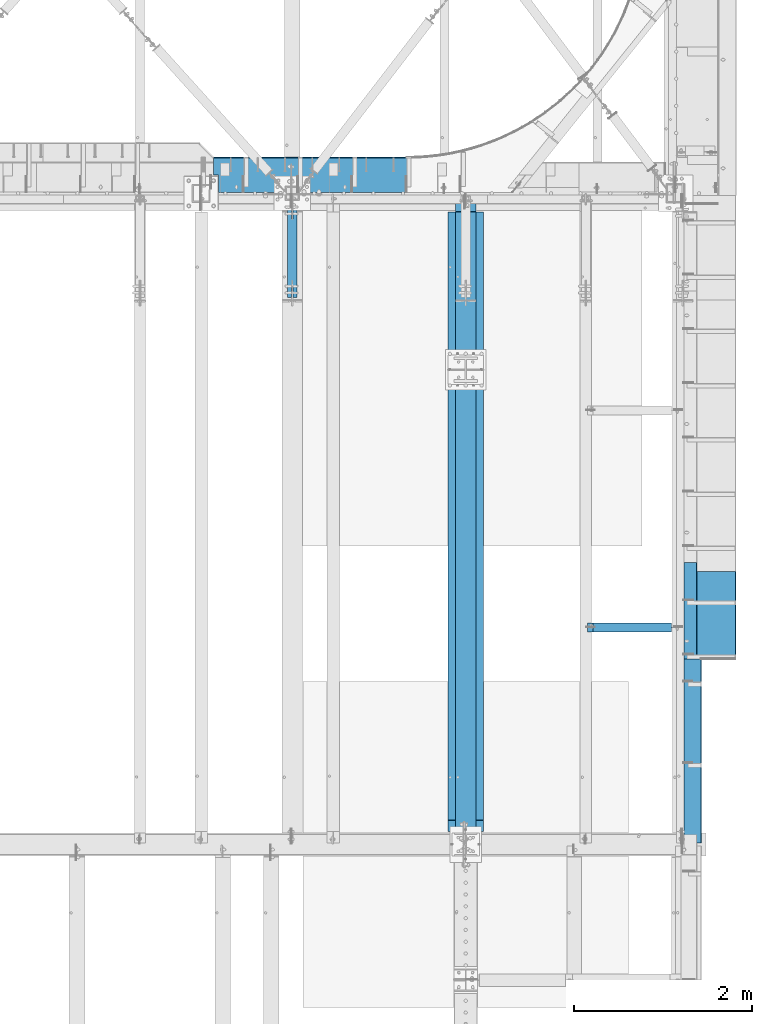
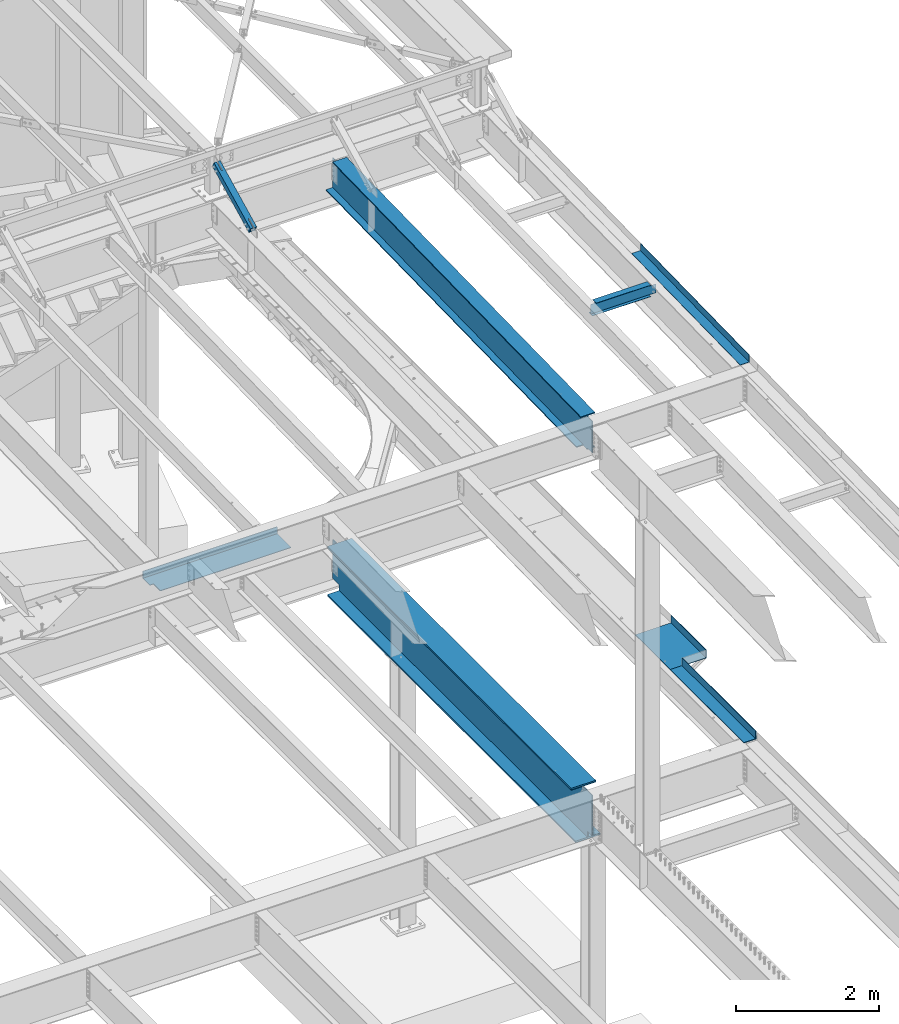
# One storey, part 1163 of 1763: 7 beams, 1 member, 7 elements without a shape of their own.
"""IFC2X3 building model written with IfcOpenShell, lengths in millimetres."""

from ifc_helpers import new_model, si_unit, frame, origin_with_axes, place, context, subcontext, project, spatial, faceted_brep, material, type_object, element, aggregate, save


model = new_model("IFC2X3")

# Units and contexts
model_context = context("Model", 3, precision=1e-05, world=origin_with_axes())
body_context = subcontext(model_context, "Body", "Model", "MODEL_VIEW")
ifc_project = project(units=[si_unit("LENGTHUNIT", "METRE", prefix="MILLI"), si_unit("AREAUNIT", "SQUARE_METRE"), si_unit("VOLUMEUNIT", "CUBIC_METRE"), si_unit("MASSUNIT", "GRAM", prefix="KILO"), si_unit("TIMEUNIT", "SECOND"), si_unit("PLANEANGLEUNIT", "RADIAN"), si_unit("SOLIDANGLEUNIT", "STERADIAN"), si_unit("THERMODYNAMICTEMPERATUREUNIT", "DEGREE_CELSIUS"), si_unit("LUMINOUSINTENSITYUNIT", "LUMEN")], contexts=[model_context])

# Site, building, storey
site_placement = place(None, origin_with_axes())
site = spatial("IfcSite", under=ifc_project, at=site_placement, CompositionType="ELEMENT")
building_placement = place(site_placement, origin_with_axes())
building = spatial("IfcBuilding", under=site, at=building_placement, Name="Undefined", CompositionType="ELEMENT")
storey_placement = place(building_placement, origin_with_axes())
storey = spatial("IfcBuildingStorey", under=building, at=storey_placement, Name="Undefined", CompositionType="ELEMENT", Elevation=0.0)

# Assembly, beam
assembly_1_placement = place(storey_placement, origin_with_axes())
assembly_1 = element("IfcElementAssembly", 1, at=assembly_1_placement, inside=storey, Name="BEAM", AssemblyPlace="NOTDEFINED", PredefinedType="RIGID_FRAME")
ifc_material_1 = material(Name="STEEL/A36")
beam_type_1 = type_object("IfcBeamType", PredefinedType="NOTDEFINED")
beam_1_placement = place(assembly_1_placement, frame((-21576.7372736984, 47380.525, 5199.0625), z_axis=(0.0, -1.0, 0.0), x_axis=(1.0, 0.0, 0.0)))
beam_1 = element("IfcBeam", 2, at=beam_1_placement, type_object=beam_type_1, material=ifc_material_1, Name="BENT_PLATE", context=body_context, shape_type="Brep", body=[
    faceted_brep([(0.0, -4.76249999999982, -492.125), (0.0, -4.76249999999982, 492.125), (0.0, 4.76249999999982, 492.125), (0.0, 4.76249999999982, -492.125), (577.849999999999, 4.76249999999982, 492.125), (577.849999999999, 4.76249999999982, -492.125), (587.375, -4.76249999999982, -492.125), (587.375, -4.76249999999982, 492.125), (577.849999999999, 134.937496948242, 492.125), (577.849999999999, 134.937496948242, -492.125), (587.375, 134.937496948242, 492.125), (587.375, 134.937496948242, -492.125)], [[[0, 1, 2, 3]], [[3, 2, 4, 5]], [[1, 0, 6, 7]], [[5, 4, 8, 9]], [[4, 2, 1, 7, 10, 8]], [[7, 6, 11, 10]], [[6, 0, 3, 5, 9, 11]], [[10, 11, 9, 8]]]),
])

assembly_2_placement = place(storey_placement, origin_with_axes())
assembly_2 = element("IfcElementAssembly", 3, at=assembly_2_placement, inside=storey, Name="BEAM", AssemblyPlace="NOTDEFINED", PredefinedType="RIGID_FRAME")
beam_type_2 = type_object("IfcBeamType", PredefinedType="NOTDEFINED")
beam_2_placement = place(assembly_2_placement, frame((-25774.4821656611, 52131.1248758608, 5199.0625), z_axis=(0.999999999984112, 5.63700000202516e-06, 0.0), x_axis=(-5.63699999961987e-06, 0.999999999984112, 0.0)))
beam_2 = element("IfcBeam", 4, at=beam_2_placement, type_object=beam_type_2, material=ifc_material_1, Name="BENT PLATE", context=body_context, shape_type="Brep", body=[
    faceted_brep([(192.880970208324, -4.76249999999982, -1030.88398011167), (192.880970208324, 4.76249999999982, -1030.88398011167), (192.881276606735, 4.76249999999982, -1086.64350000198), (192.881276606735, -4.76249999999982, -1086.64350000198), (9.60426405072212e-10, -4.76249999999982, -1030.88407867736), (9.60426405072212e-10, 4.76249999999982, -1030.88407867736), (386.58782305388, 4.76249999999982, 1086.6435000004), (-1.0113581083715e-09, 4.76249999999982, 1086.64350000145), (-1.0113581083715e-09, -4.76249999999982, 1086.64350000145), (396.112823053882, -4.76249999999982, 1086.64350000037), (396.112823047457, 122.237500452643, 1086.64349999965), (386.587823047448, 122.237500452643, 1086.64349999968), (386.58782304309, 4.76249999999982, -1086.64350000251), (386.587823049522, 122.237500439826, -1086.64350000323), (396.112823049531, 122.237500439826, -1086.64350000325), (396.112823043106, -4.76249999999982, -1086.64350000253)], [[[0, 1, 2, 3]], [[4, 5, 1, 0]], [[6, 7, 8, 9, 10, 11]], [[12, 6, 11, 13]], [[10, 14, 13, 11]], [[9, 15, 14, 10]], [[12, 13, 14, 15, 3, 2]], [[7, 6, 12, 2, 1, 5]], [[8, 7, 5, 4]], [[15, 9, 8, 4, 0, 3]]]),
])
aggregate(assembly_2, [beam_2])

assembly_3_placement = place(storey_placement, origin_with_axes())
assembly_3 = element("IfcElementAssembly", 5, at=assembly_3_placement, inside=storey, Name="BEAM", AssemblyPlace="NOTDEFINED", PredefinedType="RIGID_FRAME")
ifc_material_2 = material(Name="STEEL/A992")
beam_type_3 = type_object("IfcBeamType", Name="W8X10", PredefinedType="NOTDEFINED")
beam_3_placement = place(assembly_3_placement, frame((-22673.3396174483, 47244.0, 11546.5881832331), z_axis=(0.0, 0.0, 1.0), x_axis=(1.0, 0.0, 0.0)))
beam_3 = element("IfcBeam", 6, at=beam_3_placement, type_object=beam_type_3, material=ifc_material_2, Name="BEAM", ObjectType="W8X10", context=body_context, shape_type="Brep", body=[
    faceted_brep([(957.692640135556, 2.6814562411455, -95.25), (957.692640136163, 2.6810410749822, -100.012500000001), (957.692569353068, 50.8000000000029, -100.012500000001), (957.692569353068, 50.8000000000029, -95.25), (1065.64272309272, 2.68161503600277, -95.25), (1065.64272309272, 2.6811998698322, -100.012500000001), (74.2523437499622, 2.38124999999854, 95.25), (74.2523437499622, 50.8000000000029, 95.25), (956.898971566847, 50.8000000000029, 95.25), (956.898971566847, 2.38124999999854, 95.25), (74.2523437499622, -50.8000000000029, 100.012500000001), (74.2523437499622, 50.8000000000029, 100.012500000001), (74.2523437499622, 2.38124999999854, 80.7025014875653), (74.2523437499622, -2.38124999999854, 80.7025014875653), (74.2523437499622, -2.38124999999854, 95.25), (74.2523437499622, -50.8000000000029, 95.25), (73.2856138273746, 2.38124999999854, 75.8424219695189), (73.2856138273746, -2.38124999999854, 75.8424219695189), (70.5325999268971, 2.38124999999854, 71.7222455013653), (70.5325999268971, -2.38124999999854, 71.7222455013653), (66.4124234587434, 2.38124999999854, 68.9692316008877), (66.4124234587434, -2.38124999999854, 68.9692316008877), (61.552343940697, 2.38124999999854, 68.0025016783002), (61.552343940697, -2.38124999999854, 68.0025016783002), (10.7523437499694, 2.38124999999854, 68.0025016783002), (10.7523437499694, -2.38124999999854, 68.0025016783002), (10.7523437499694, 2.38124999999854, -95.25), (10.7523437499694, 50.8000000000029, -95.25), (10.7523437499694, 50.8000000000029, -100.012500000001), (10.7523437499694, -50.8000000000029, -100.012500000001), (10.7523437499694, -50.8000000000029, -95.25), (10.7523437499694, -2.38124999999854, -95.25), (957.692715737423, -50.8000000000029, -100.012500000001), (957.692715737423, -50.8000000000029, -95.25), (957.692644955085, -2.68145587174513, -100.012500000001), (957.692644954477, -2.68104070558184, -95.25), (1065.64272309272, -2.68088191115385, -95.25), (1065.64272309272, -2.68129707733169, -100.012500000001), (1065.64272309272, -2.38124999999854, -95.25), (969.598971376112, -2.38124999999854, 50.7402008918289), (965.540739476481, -2.38124999999854, 51.5474334063601), (964.738891858065, -2.38124999999854, 51.7069308144164), (960.618715389912, -2.38124999999854, 54.4599447148939), (957.865701489434, -2.38124999999854, 58.5801211830476), (956.898971566847, -2.38124999999854, 63.440200701094), (956.898971566847, -2.38124999999854, 95.25), (1065.64272309272, -2.38124999999854, 50.7402008918289), (970.392722901983, -2.38124999999854, 50.7402008918289), (956.898971566847, -50.8000000000029, 95.25), (956.898971566847, -50.8000000000029, 100.012500000001), (956.898971566847, 50.8000000000029, 100.012500000001), (956.898971566847, 2.38124999999854, 63.440200701094), (957.865701489434, 2.38124999999854, 58.5801211830476), (960.618715389912, 2.38124999999854, 54.4599447148939), (964.738891858065, 2.38124999999854, 51.7069308144164), (969.598971376112, 2.38124999999854, 50.7402008918289), (965.540739476481, 2.38124999999854, 51.5474334063601), (1065.64272309272, 2.38124999999854, 50.7402008918289), (970.392722901983, 2.38124999999854, 50.7402008918289), (1065.64272309272, 2.38124999999854, -95.25)], [[[0, 1, 2, 3]], [[4, 5, 1, 0]], [[6, 7, 8, 9]], [[10, 11, 7, 6, 12, 13, 14, 15]], [[13, 12, 16, 17]], [[17, 16, 18, 19]], [[19, 18, 20, 21]], [[21, 20, 22, 23]], [[23, 22, 24, 25]], [[26, 27, 28, 29, 30, 31, 25, 24]], [[30, 29, 32, 33]], [[33, 32, 34, 35]], [[36, 35, 34, 37]], [[38, 31, 30, 33, 35, 36]], [[39, 40, 41, 42, 43, 44, 45, 14, 13, 17, 19, 21, 23, 25, 31, 38, 46, 47]], [[15, 14, 45, 48]], [[10, 15, 48, 49]], [[11, 10, 49, 50]], [[7, 11, 50, 8]], [[49, 48, 45, 44, 51, 9, 8, 50]], [[43, 52, 51, 44]], [[42, 53, 52, 43]], [[41, 54, 53, 42]], [[40, 39, 55, 56, 54, 41]], [[47, 46, 57, 58, 55, 39]], [[57, 59, 26, 24, 22, 20, 18, 16, 12, 6, 9, 51, 52, 53, 54, 56, 55, 58]], [[3, 27, 26, 59, 4, 0]], [[28, 27, 3, 2]], [[37, 34, 32, 29, 28, 2, 1, 5]], [[59, 57, 46, 38, 36, 37, 5, 4]]]),
])
aggregate(assembly_3, [beam_3])

# Assembly, member
assembly_4_placement = place(storey_placement, origin_with_axes())
assembly_4 = element("IfcElementAssembly", 7, at=assembly_4_placement, inside=storey, Name="BEAM", AssemblyPlace="NOTDEFINED", PredefinedType="RIGID_FRAME")
ifc_material_3 = material()
member_type = type_object("IfcMemberType", Name="HSS4X4X1/2", PredefinedType="NOTDEFINED")
member_placement = place(assembly_4_placement, frame((-25976.6096174484, 50822.4448748991, 11720.6374724137), z_axis=(-1.0, 0.0, 0.0), x_axis=(0.0, 0.894427191199916, 0.447213595099959)))
member = element("IfcMember", 8, at=member_placement, type_object=member_type, material=ifc_material_3, Name="BEAM", ObjectType="HSS4X4X1/2", context=body_context, shape_type="Brep", body=[
    faceted_brep([(166.342448712421, -50.8000000002612, 7.93750000025466), (166.342448712407, -38.100000000255, 7.93750000025466), (317.154945941751, -38.1000000004733, 7.93750000025466), (317.154945941787, -50.8000000004795, 7.93750000025466), (320.192495686126, -38.1000000004788, 7.33329378956478), (320.192495686155, -50.8000000004849, 7.33329378956478), (322.767606017376, -38.1000000004806, 5.61266007592349), (322.767606017405, -50.8000000004849, 5.61266007592349), (324.488239731007, -38.1000000004842, 3.03754974465119), (324.488239731028, -50.800000000494, 3.03754974465119), (317.154945941773, -50.8000000004795, -7.93749999987267), (317.154945941751, -38.1000000004715, -7.93749999987267), (166.342448712407, -38.100000000255, -7.93749999974898), (166.342448712421, -50.8000000002612, -7.93749999974898), (320.192495686155, -50.8000000004831, -7.33329378918279), (320.192495686126, -38.1000000004769, -7.33329378918279), (322.767606017391, -50.8000000004868, -5.61266007554514), (322.767606017376, -38.1000000004806, -5.61266007554514), (324.488239731028, -50.800000000494, -3.03754974427284), (324.488239731007, -38.1000000004842, -3.03754974427284), (325.092445941715, -50.8000000004904, 2.5465851649642e-10), (325.092445941693, -38.1000000004842, 2.5465851649642e-10), (166.342448712276, 38.0999999997875, 7.93750000025466), (166.342448712254, 50.7999999997955, 7.93750000025466), (317.154945941591, 50.7999999995791, 7.93750000025466), (317.15494594162, 38.0999999995711, 7.93750000025466), (320.192495685966, 50.7999999995736, 7.33329378956478), (320.192495685995, 38.0999999995693, 7.33329378956478), (322.767606017216, 50.7999999995718, 5.61266007592349), (322.767606017245, 38.0999999995638, 5.61266007592349), (324.488239730847, 50.7999999995682, 3.03754974465119), (324.488239730868, 38.0999999995638, 3.03754974465119), (317.154945941606, 38.0999999995693, -7.93749999987267), (317.154945941591, 50.7999999995791, -7.93749999987267), (166.342448712254, 50.7999999997955, -7.93749999974898), (166.342448712276, 38.0999999997875, -7.93749999974898), (320.19249568598, 38.0999999995674, -7.33329378918279), (320.192495685966, 50.7999999995754, -7.33329378918279), (322.767606017245, 38.0999999995638, -5.61266007554514), (322.767606017209, 50.79999999957, -5.61266007554514), (324.488239730861, 38.0999999995602, -3.03754974427284), (324.488239730847, 50.7999999995682, -3.03754974427284), (325.092445941555, 38.0999999995583, 2.5465851649642e-10), (325.092445941533, 50.7999999995682, 2.5465851649642e-10), (166.342448712407, -38.100000000255, 38.0999999999985), (166.342448712276, 38.0999999997875, 38.0999999999985), (1312.61289971639, 38.0999999981505, 38.0999999999985), (1312.61289971651, -38.1000000018903, 38.0999999999985), (166.342448712254, 50.7999999997955, 50.7999999999993), (1312.61289971636, 50.7999999981585, 50.7999999999993), (1312.61289971636, 50.7999999981585, 7.9375), (1161.80039971021, 50.7999999983731, 7.9375), (1158.76284996585, 50.7999999983786, 7.33329378931012), (1156.18773963459, 50.7999999983804, 5.61266007566883), (1154.46710592096, 50.7999999983858, 3.03754974439653), (1153.86289971027, 50.7999999983858, 0.0), (1154.46710592096, 50.7999999983858, -3.03754974439653), (1156.18773963459, 50.7999999983804, -5.61266007566883), (1158.76284996585, 50.7999999983786, -7.33329378931012), (1161.80039971021, 50.7999999983731, -7.9375), (1312.61289971636, 50.7999999981585, -7.9375), (1312.61289971636, 50.7999999981585, -50.7999999999993), (166.342448712254, 50.7999999997955, -50.7999999999993), (1312.61289971639, 38.0999999981505, 7.9375), (1161.80039971024, 38.0999999983687, 7.9375), (1158.76284996586, 38.0999999983705, 7.33329378931012), (1156.18773963462, 38.099999998376, 5.61266007566883), (1154.46710592099, 38.0999999983778, 3.03754974439653), (1153.86289971031, 38.0999999983796, 0.0), (1154.46710592099, 38.0999999983778, -3.03754974439653), (1156.18773963462, 38.099999998376, -5.61266007566883), (1158.76284996586, 38.0999999983705, -7.33329378931012), (1161.80039971024, 38.0999999983687, -7.9375), (1312.61289971639, 38.0999999981505, -7.9375), (166.342448712276, 38.0999999997875, -38.0999999999985), (166.342448712407, -38.100000000255, -38.0999999999985), (1312.61289971651, -38.1000000018903, -38.0999999999985), (1312.61289971639, 38.0999999981505, -38.0999999999985), (1158.76284996603, -50.8000000016782, 7.33329378931012), (1158.762849966, -38.1000000016738, 7.33329378931012), (1161.80039971038, -38.1000000016793, 7.9375), (1161.8003997104, -50.8000000016891, 7.9375), (1156.18773963477, -50.8000000016764, 5.61266007566883), (1156.18773963476, -38.1000000016684, 5.61266007566883), (1154.46710592115, -50.8000000016727, 3.03754974439653), (1154.46710592113, -38.1000000016629, 3.03754974439653), (1153.86289971046, -50.8000000016746, 0.0), (1153.86289971044, -38.1000000016684, 0.0), (1154.46710592115, -50.8000000016727, -3.03754974439653), (1154.46710592113, -38.1000000016629, -3.03754974439653), (1156.18773963477, -50.8000000016764, -5.61266007566883), (1156.18773963476, -38.1000000016684, -5.61266007566883), (1158.76284996603, -50.8000000016782, -7.33329378931012), (1158.762849966, -38.1000000016738, -7.33329378931012), (1161.8003997104, -50.8000000016891, -7.9375), (1161.80039971038, -38.1000000016793, -7.9375), (1312.61289971653, -50.8000000018983, -7.9375), (1312.61289971651, -38.1000000018903, -7.9375), (1312.61289971653, -50.8000000018983, -50.7999999999993), (166.342448712421, -50.8000000002612, -50.7999999999993), (1312.61289971651, -38.1000000018903, 7.9375), (1312.61289971653, -50.8000000018983, 7.9375), (1312.61289971653, -50.8000000018983, 50.7999999999993), (166.342448712421, -50.8000000002612, 50.7999999999993)], [[[0, 1, 2, 3]], [[3, 2, 4, 5]], [[5, 4, 6, 7]], [[7, 6, 8, 9]], [[10, 11, 12, 13]], [[14, 15, 11, 10]], [[16, 17, 15, 14]], [[18, 19, 17, 16]], [[20, 21, 19, 18]], [[9, 8, 21, 20]], [[22, 23, 24, 25]], [[25, 24, 26, 27]], [[27, 26, 28, 29]], [[29, 28, 30, 31]], [[32, 33, 34, 35]], [[36, 37, 33, 32]], [[38, 39, 37, 36]], [[40, 41, 39, 38]], [[42, 43, 41, 40]], [[31, 30, 43, 42]], [[44, 45, 46, 47]], [[28, 26, 24, 23, 48, 49, 50, 51, 52, 53, 54, 55, 56, 57, 58, 59, 60, 61, 62, 34, 33, 37, 39, 41, 43, 30]], [[63, 64, 51, 50]], [[65, 52, 51, 64]], [[66, 53, 52, 65]], [[67, 54, 53, 66]], [[68, 55, 54, 67]], [[69, 56, 55, 68]], [[70, 57, 56, 69]], [[71, 58, 57, 70]], [[72, 59, 58, 71]], [[73, 60, 59, 72]], [[74, 75, 76, 77]], [[78, 79, 80, 81]], [[82, 83, 79, 78]], [[84, 85, 83, 82]], [[86, 87, 85, 84]], [[88, 89, 87, 86]], [[90, 91, 89, 88]], [[92, 93, 91, 90]], [[94, 95, 93, 92]], [[96, 97, 95, 94]], [[98, 61, 60, 73, 77, 76, 97, 96]], [[99, 62, 61, 98]], [[75, 74, 35, 34, 62, 99, 13, 12]], [[6, 4, 2, 1, 44, 47, 100, 80, 79, 83, 85, 87, 89, 91, 93, 95, 97, 76, 75, 12, 11, 15, 17, 19, 21, 8]], [[101, 81, 80, 100]], [[47, 46, 63, 50, 49, 102, 101, 100]], [[48, 103, 102, 49]], [[16, 14, 10, 13, 99, 98, 96, 94, 92, 90, 88, 86, 84, 82, 78, 81, 101, 102, 103, 0, 3, 5, 7, 9, 20, 18]], [[103, 48, 23, 22, 45, 44, 1, 0]], [[38, 36, 32, 35, 74, 77, 73, 72, 71, 70, 69, 68, 67, 66, 65, 64, 63, 46, 45, 22, 25, 27, 29, 31, 42, 40]]]),
])
aggregate(assembly_4, [member])

# Beam
beam_type_4 = type_object("IfcBeamType", PredefinedType="NOTDEFINED")
beam_4_placement = place(assembly_1_placement, frame((-21576.7372736984, 45856.525, 5199.0625), z_axis=(0.0, -1.0, 0.0), x_axis=(1.0, 0.0, 0.0)))
beam_4 = element("IfcBeam", 9, at=beam_4_placement, type_object=beam_type_4, material=ifc_material_1, Name="BENT_PLATE", context=body_context, shape_type="Brep", body=[
    faceted_brep([(0.0, -4.76249999999982, -1031.875), (0.0, -4.76249999999982, 1031.875), (0.0, 4.76249999999982, 1031.875), (0.0, 4.76249999999982, -1031.875), (190.499993896483, 4.76249999999982, 1031.875), (190.499993896483, 4.76249999999982, -1031.875), (200.024993896484, -4.76249999999982, -1031.875), (200.024993896484, -4.76249999999982, 1031.875), (190.499993896483, 134.937496948242, 1031.875), (190.499993896483, 134.937496948242, -1031.875), (200.024993896484, 134.937496948242, 1031.875), (200.024993896484, 134.937496948242, -1031.875)], [[[0, 1, 2, 3]], [[3, 2, 4, 5]], [[1, 0, 6, 7]], [[5, 4, 8, 9]], [[4, 2, 1, 7, 10, 8]], [[7, 6, 11, 10]], [[6, 0, 3, 5, 9, 11]], [[10, 11, 9, 8]]]),
])

aggregate(assembly_1, [beam_1, beam_4])

# Assembly, beam
assembly_5_placement = place(storey_placement, origin_with_axes())
assembly_5 = element("IfcElementAssembly", 10, at=assembly_5_placement, inside=storey, Name="BEAM", AssemblyPlace="NOTDEFINED", PredefinedType="RIGID_FRAME")
beam_type_5 = type_object("IfcBeamType", PredefinedType="NOTDEFINED")
beam_5_placement = place(assembly_5_placement, frame((-21576.7406443556, 46449.9787297125, 11633.3483367225), z_axis=(0.0, -0.999786037781472, -0.0206852279954809), x_axis=(1.0, 0.0, 0.0)))
beam_5 = element("IfcBeam", 11, at=beam_5_placement, type_object=beam_type_5, material=ifc_material_1, Name="BENT_PLATE", context=body_context, shape_type="Brep", body=[
    faceted_brep([(0.0, -3.17499999999927, -1523.99999999999), (0.0, -3.17499999999927, 1524.0), (0.0, 3.17499999999927, 1524.0), (0.0, 3.17499999999927, -1523.99999999999), (142.87500610367, 3.17500000040309, 1524.00000000439), (142.875006103837, 3.17499999959364, -1524.00000000439), (149.225006103836, -3.17500000040127, -1524.00000000439), (149.225006103668, -3.17499999959364, 1524.00000000439), (142.875006103754, 123.824997298818, 1524.00000000437), (142.875006103754, 123.824997298098, -1524.00000000442), (149.225006103752, 123.824997298818, 1524.00000000437), (149.225006103752, 123.824997298098, -1524.00000000442)], [[[0, 1, 2, 3]], [[3, 2, 4, 5]], [[1, 0, 6, 7]], [[5, 4, 8, 9]], [[4, 2, 1, 7, 10, 8]], [[7, 6, 11, 10]], [[6, 0, 3, 5, 9, 11]], [[10, 11, 9, 8]]]),
])
aggregate(assembly_5, [beam_5])

assembly_6_placement = place(storey_placement, origin_with_axes())
assembly_6 = element("IfcElementAssembly", 12, at=assembly_6_placement, inside=storey, Name="BEAM", AssemblyPlace="NOTDEFINED", PredefinedType="RIGID_FRAME")
beam_type_6 = type_object("IfcBeamType", Name="W24X76", PredefinedType="NOTDEFINED")
beam_6_placement = place(assembly_6_placement, frame((-24027.8372736984, 44811.8720196671, 11293.0034049879), z_axis=(0.0, -0.0206852279954837, 0.999786037781472), x_axis=(0.0, 0.999786037781472, 0.0206852279954825)))
beam_6 = element("IfcBeam", 13, at=beam_6_placement, type_object=beam_type_6, material=ifc_material_2, Name="BEAM", ObjectType="W24X76", context=body_context, shape_type="Brep", body=[
    faceted_brep([(259.713420868648, 5.55625000003056, -285.749999999851), (259.713420868648, 5.55625000003056, -303.212499999838), (145.413433073838, 5.55625000000873, -303.212499999807), (145.413433073845, 5.55625000000146, -285.749999999822), (259.713420868648, 114.299999999999, -285.749999999851), (259.713420868648, 114.299999999999, -303.212499999838), (7281.55640465069, -5.55625000000146, -285.750000001717), (7292.02852510743, -5.55625000000146, 220.402497851217), (7122.36847335724, -5.55625000000146, 220.402497851248), (7117.50839383915, -5.55625000000146, 221.369227773837), (7113.38821737097, -5.55625000000146, 224.122241674309), (7110.63520347048, -5.55625000000146, 228.242418142454), (7109.66847354787, -5.55625000000146, 233.102497660489), (7109.66847354787, -5.55625000000146, 285.749999997897), (145.413433073918, -5.55625000000146, 285.749999999749), (145.413433073918, -5.55625000000146, 284.162499808659), (144.446703151327, -5.55625000000146, 279.302420290625), (141.693689250824, -5.55625000000146, 275.182243822481), (137.573512782641, -5.55625000000146, 272.429229922011), (132.713433264544, -5.55625000000146, 271.462499999427), (100.170926805149, -5.55625000000146, 271.462499999434), (17.6032604435895, -5.55625000000146, 271.46249999945), (6.37032961133809, -5.55625000000146, -271.462499999152), (88.9379959728903, -5.55625000000146, -271.462499999199), (132.713433264471, -5.55625000000146, -271.462499999225), (137.573512782561, -5.55625000000146, -272.42922992181), (141.693689250744, -5.55625000000146, -275.182243822283), (144.446703151247, -5.55625000000146, -279.302420290427), (145.413433073845, -5.55625000000146, -284.162499808463), (145.413433073845, -5.55625000000146, -285.749999999822), (7281.55640465069, -114.299999999999, -285.750000001717), (145.413433073845, -114.299999999999, -285.749999999822), (7281.19511155374, -114.299999999999, -303.212500001704), (145.413433073838, -114.299999999999, -303.212499999807), (7281.19511155374, 114.299999999999, -303.212500001704), (7281.55640465069, 114.299999999999, -285.750000001717), (7281.55640465069, 5.55625000000146, -285.750000001717), (7292.02852510743, 5.55625000000146, 220.402497851217), (7122.36847335724, 5.55625000000146, 220.402497851248), (7117.50839383915, 5.55625000000146, 221.369227773837), (7113.38821737097, 5.55625000000146, 224.122241674309), (7110.63520347048, 5.55625000000146, 228.242418142454), (7109.66847354787, 5.55625000000146, 233.102497660489), (7109.66847354788, -114.299999999999, 303.212499997884), (7109.66847354787, -114.299999999999, 285.749999997897), (7109.66847354787, 5.55625000000146, 285.749999997897), (7109.66847354787, 114.299999999999, 285.749999997897), (7109.66847354788, 114.299999999999, 303.212499997884), (145.413433073918, 5.55625000000146, 285.749999999749), (145.413433073918, 114.299999999999, 285.749999999749), (145.413433073918, 114.299999999999, 303.212499999736), (145.413433073918, -114.299999999999, 303.212499999736), (145.413433073918, -114.299999999999, 285.749999999749), (145.413433073918, 5.55625000000146, 284.162499808659), (144.446703151327, 5.55625000000146, 279.302420290625), (141.693689250824, 5.55625000000146, 275.182243822481), (137.573512782641, 5.55625000000146, 272.429229922011), (132.713433264544, 5.55625000000146, 271.462499999427), (100.170926805149, 5.55625000000146, 271.462499999434), (17.6032604435895, 5.55625000000146, 271.46249999945), (6.37032961133809, 5.55625000000146, -271.462499999152), (88.9379959728903, 5.55625000000146, -271.462499999199), (132.713433264471, 5.55625000000146, -271.462499999225), (137.573512782561, 5.55625000000146, -272.42922992181), (141.693689250744, 5.55625000000146, -275.182243822283), (144.446703151247, 5.55625000000146, -279.302420290427), (145.413433073845, 5.55625000000146, -284.162499808463)], [[[0, 1, 2, 3]], [[4, 5, 1, 0]], [[6, 7, 8, 9, 10, 11, 12, 13, 14, 15, 16, 17, 18, 19, 20, 21, 22, 23, 24, 25, 26, 27, 28, 29]], [[30, 6, 29, 31]], [[32, 30, 31, 33]], [[6, 30, 32, 34, 35, 36, 37, 7]], [[7, 37, 38, 8]], [[8, 38, 39, 9]], [[9, 39, 40, 10]], [[10, 40, 41, 11]], [[11, 41, 42, 12]], [[43, 44, 13, 12, 42, 45, 46, 47]], [[46, 45, 48, 49]], [[47, 46, 49, 50]], [[43, 47, 50, 51]], [[44, 43, 51, 52]], [[13, 44, 52, 14]], [[51, 50, 49, 48, 53, 15, 14, 52]], [[15, 53, 54, 16]], [[16, 54, 55, 17]], [[17, 55, 56, 18]], [[18, 56, 57, 19]], [[20, 19, 57, 58, 59, 21]], [[21, 59, 60, 22]], [[23, 22, 60, 61, 62, 24]], [[24, 62, 63, 25]], [[25, 63, 64, 26]], [[26, 64, 65, 27]], [[27, 65, 66, 28]], [[64, 63, 62, 61, 60, 59, 58, 57, 56, 55, 54, 53, 48, 45, 42, 41, 40, 39, 38, 37, 36, 0, 3, 66, 65]], [[33, 31, 29, 28, 66, 3, 2]], [[34, 32, 33, 2, 1, 5]], [[35, 34, 5, 4]], [[36, 35, 4, 0]]]),
])
aggregate(assembly_6, [beam_6])

assembly_7_placement = place(storey_placement, origin_with_axes())
assembly_7 = element("IfcElementAssembly", 14, at=assembly_7_placement, inside=storey, Name="BEAM", AssemblyPlace="NOTDEFINED", PredefinedType="RIGID_FRAME")
beam_type_7 = type_object("IfcBeamType", Name="W33X201", PredefinedType="NOTDEFINED")
beam_7_placement = place(assembly_7_placement, frame((-24027.8372736984, 44805.6, 4767.2625), z_axis=(0.0, 0.0, 1.0), x_axis=(0.0, 1.0, 0.0)))
beam_7 = element("IfcBeam", 15, at=beam_7_placement, type_object=beam_type_7, material=ifc_material_2, Name="BEAM", ObjectType="W33X201", context=body_context, shape_type="Brep", body=[
    faceted_brep([(19.0499999999811, -8.73125000000073, -296.862500000001), (19.0499999999811, 8.73125000000073, -296.862500000001), (133.350000190723, 8.73125000000073, -296.862500000001), (133.350000190723, -8.73125000000073, -296.862500000001), (138.21007970877, 8.73125000000073, -297.829229922589), (138.21007970877, -8.73125000000073, -297.829229922589), (142.330256176923, 8.73125000000073, -300.582243823067), (142.330256176923, -8.73125000000073, -300.582243823067), (145.083270077397, 8.73125000000073, -304.702420291221), (145.083270077397, -8.73125000000073, -304.702420291221), (146.049999999988, -8.73125000000073, -309.562499809266), (146.049999999988, 8.73125000000073, -309.562499809266), (146.049999999988, 8.73125000000073, -398.4625), (146.049999999988, 200.025000000001, -398.4625), (146.049999999988, 200.025000000001, -427.0375), (146.049999999988, -200.025000000001, -427.0375), (146.049999999988, -200.025000000001, -398.4625), (146.049999999988, -8.73125000000073, -398.4625), (7108.03124999999, 200.025000000001, 398.4625), (7108.03124999999, 8.73125000000073, 398.4625), (268.514989432144, 8.73125000000073, 398.4625), (268.514989432144, 200.025000000001, 398.4625), (260.350000190723, -8.73125000000073, 395.287499999999), (260.350000190723, 8.73125000000073, 395.287499999999), (19.0499999999811, 8.73125000000073, 395.287499999999), (19.0499999999811, -8.73125000000073, 395.287499999999), (265.21007970877, -8.73125000000073, 396.254229922587), (265.21007970877, 8.73125000000073, 396.254229922587), (7108.03124999999, -200.025000000001, 427.0375), (7108.03124999999, 200.025000000001, 427.0375), (273.049999999988, 200.025000000001, 427.0375), (273.049999999988, -200.025000000001, 427.0375), (272.083270077397, -200.025000000001, 403.127420291219), (269.330256176923, -200.025000000001, 399.007243823065), (268.514989432144, -200.025000000001, 398.4625), (7108.03124999999, -200.025000000001, 398.4625), (273.049999999988, -200.025000000001, 407.987499809265), (7108.03124999999, -8.73125000000073, 398.4625), (268.514989432144, -8.73125000000073, 398.4625), (269.330256176923, 200.025000000001, 399.007243823065), (272.083270077397, 200.025000000001, 403.127420291219), (273.049999999988, 200.025000000001, 407.987499809265), (7108.03124999999, -8.73125000000073, 375.977497673035), (7108.03124999999, 8.73125000000073, 375.977497673035), (7108.99797992257, -8.73125000000073, 371.11741815499), (7108.99797992257, 8.73125000000073, 371.11741815499), (7111.75099382305, -8.73125000000073, 366.997241686836), (7111.75099382305, 8.73125000000073, 366.997241686836), (7115.8711702912, -8.73125000000073, 364.244227786357), (7115.8711702912, 8.73125000000073, 364.244227786357), (7120.73124980925, -8.73125000000073, 363.27749786377), (7120.73124980925, 8.73125000000073, 363.27749786377), (7292.18124999999, -8.73125000000073, 363.27749786377), (7292.18124999999, 8.73125000000073, 363.27749786377), (7292.18124999999, -8.73125000000073, -300.297499999999), (7292.18124999999, 8.73125000000073, -300.297499999999), (7120.73124980925, -8.73125000000073, -300.297499999999), (7120.73124980925, 8.73125000000073, -300.297499999999), (7115.8711702912, -8.73125000000073, -301.264229922586), (7115.8711702912, 8.73125000000073, -301.264229922586), (7111.75099382305, -8.73125000000073, -304.017243823065), (7111.75099382305, 8.73125000000073, -304.017243823065), (7108.99797992257, -8.73125000000073, -308.137420291218), (7108.99797992257, 8.73125000000073, -308.137420291218), (7108.03124999999, -8.73125000000073, -312.997499809264), (7108.03124999999, 8.73125000000073, -312.997499809264), (7108.03124999999, -8.73125000000073, -398.4625), (7108.03124999999, -200.025000000001, -398.4625), (7108.03124999999, -200.025000000001, -427.0375), (7108.03124999999, 200.025000000001, -427.0375), (7108.03124999999, 200.025000000001, -398.4625), (7108.03124999999, 8.73125000000073, -398.4625)], [[[0, 1, 2, 3]], [[3, 2, 4, 5]], [[5, 4, 6, 7]], [[7, 6, 8, 9]], [[10, 11, 12, 13, 14, 15, 16, 17]], [[9, 8, 11, 10]], [[18, 19, 20, 21]], [[22, 23, 24, 25]], [[26, 27, 23, 22]], [[28, 29, 30, 31]], [[32, 33, 34, 35, 28, 31, 36]], [[37, 35, 34, 38]], [[33, 39, 21, 20, 27, 26, 38, 34]], [[32, 40, 39, 33]], [[36, 41, 40, 32]], [[31, 30, 41, 36]], [[29, 18, 21, 39, 40, 41, 30]], [[28, 35, 37, 42, 43, 19, 18, 29]], [[44, 45, 43, 42]], [[46, 47, 45, 44]], [[48, 49, 47, 46]], [[50, 51, 49, 48]], [[52, 53, 51, 50]], [[53, 52, 54, 55]], [[54, 56, 57, 55]], [[58, 59, 57, 56]], [[60, 61, 59, 58]], [[62, 63, 61, 60]], [[64, 65, 63, 62]], [[66, 67, 68, 69, 70, 71, 65, 64]], [[67, 66, 17, 16]], [[68, 67, 16, 15]], [[69, 68, 15, 14]], [[70, 69, 14, 13]], [[71, 70, 13, 12]], [[6, 4, 2, 1, 24, 23, 27, 20, 19, 43, 45, 47, 49, 51, 53, 55, 57, 59, 61, 63, 65, 71, 12, 11, 8]], [[25, 24, 1, 0]], [[66, 64, 62, 60, 58, 56, 54, 52, 50, 48, 46, 44, 42, 37, 38, 26, 22, 25, 0, 3, 5, 7, 9, 10, 17]]]),
])
aggregate(assembly_7, [beam_7])

save(model, "model.ifc")
